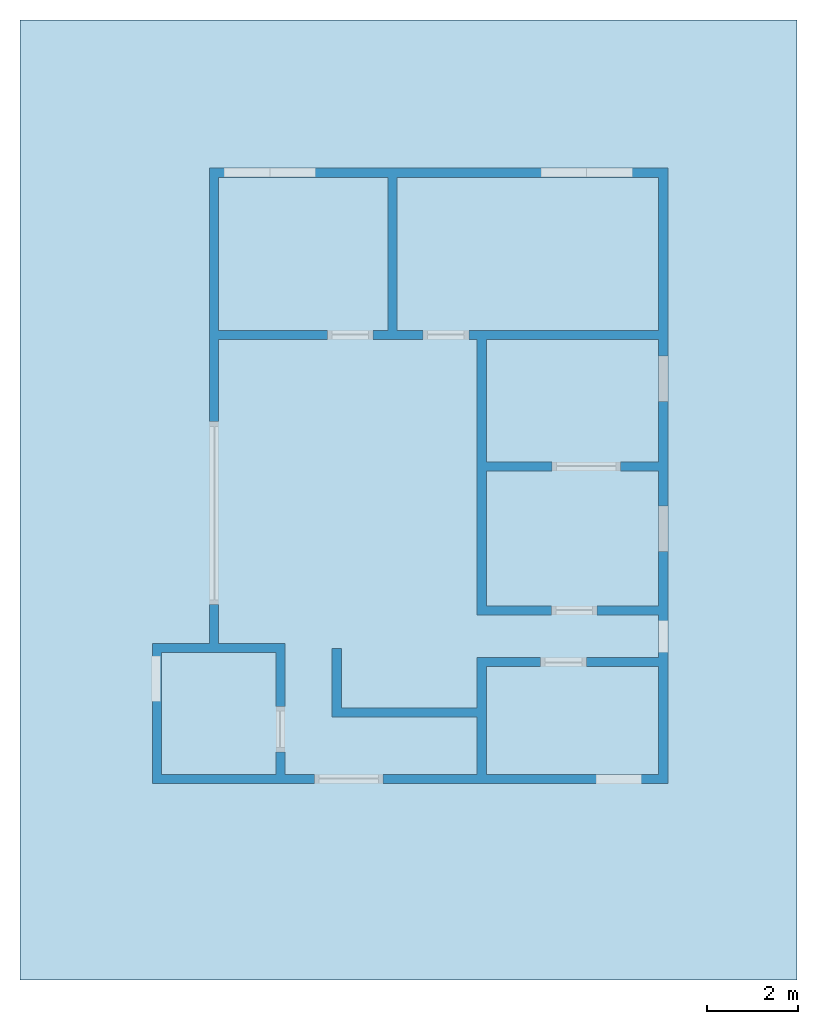
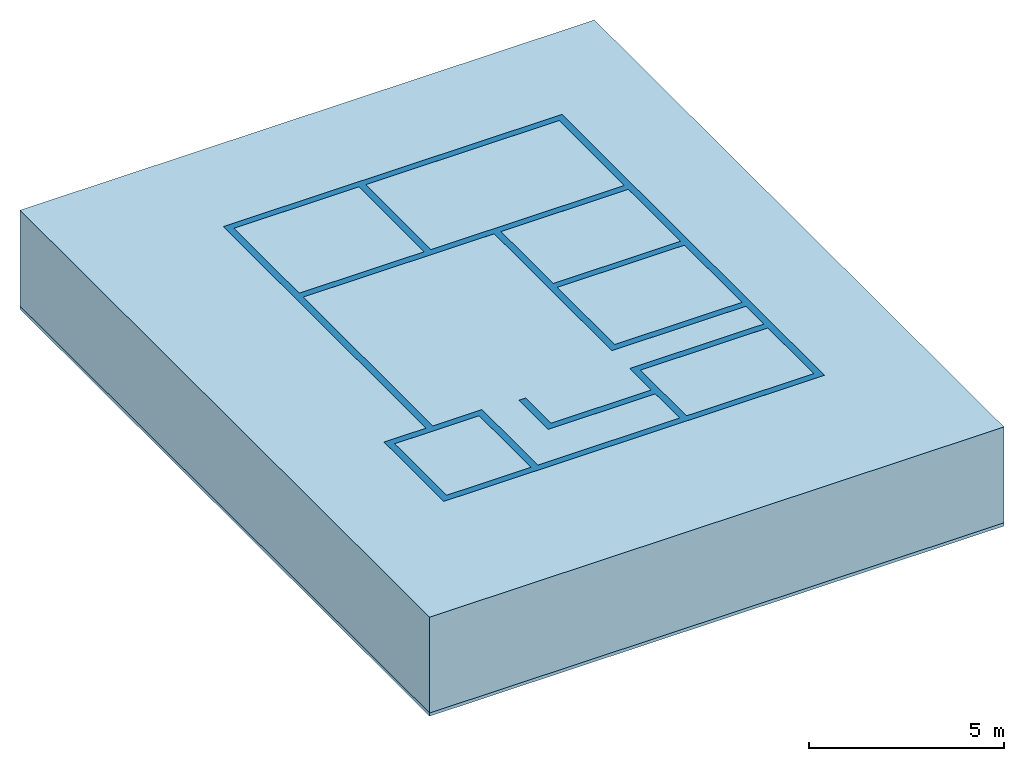
# Not in any storey, part 1 of 2: 2 plates, 1 wall, 17 openings.
"""IFC4 building model written with IfcOpenShell, lengths in metres."""

from ifc_helpers import new_model, entity, si_unit, converted_unit, direction, frame, frame_2d, origin_with_axes, place, context, subcontext, project, spatial, polyline, rectangle, outline, extrude, faceted_brep, element, save


model = new_model("IFC4")

# Units and contexts
model_context = context("Model", 3, precision=1e-05, world=origin_with_axes(), true_north=direction((0.0, 1.0)))
body_context = subcontext(model_context, "Body", "Model", "MODEL_VIEW")
ifc_project = project(units=[si_unit("LENGTHUNIT", "METRE"), si_unit("AREAUNIT", "SQUARE_METRE"), si_unit("VOLUMEUNIT", "CUBIC_METRE"), converted_unit("PLANEANGLEUNIT", "DEGREE", entity("IfcPlaneAngleMeasure", 0.017453292519943295), si_unit("PLANEANGLEUNIT", "RADIAN"), dimensions=[0, 0, 0, 0, 0, 0, 0])], contexts=[model_context])

# Building
building = spatial("IfcBuilding", Name="002", CompositionType="COMPLEX")

# Plates
placement = place(None, origin_with_axes())
element("IfcPlate", 1, at=placement, inside=building, Name="Panel", PredefinedType="CURTAIN_PANEL", context=body_context, shape_type="Brep", body=[
    faceted_brep([(14.0, -6.0, -0.1), (14.0, -6.0, 0.0), (-3.0, -6.0, 0.0), (-3.0, -6.0, -0.1), (14.0, 15.0, -0.1), (14.0, 15.0, 0.0), (-3.0, 15.0, -0.1), (-3.0, 15.0, 0.0)], [[[0, 1, 2, 3]], [[4, 5, 1, 0]], [[6, 7, 5, 4]], [[3, 2, 7, 6]], [[6, 4, 0, 3]], [[2, 1, 5, 7]]]),
])
element("IfcPlate", 2, at=placement, inside=building, Name="Panel001", PredefinedType="CURTAIN_PANEL", context=body_context, shape_type="Brep", body=[
    faceted_brep([(14.0, -6.0, 0.0), (14.0, -6.0, 3.0), (-3.0, -6.0, 3.0), (-3.0, -6.0, 0.0), (14.0, 15.0, 0.0), (14.0, 15.0, 3.0), (-3.0, 15.0, 0.0), (-3.0, 15.0, 3.0)], [[[0, 1, 2, 3]], [[4, 5, 1, 0]], [[6, 7, 5, 4]], [[3, 2, 7, 6]], [[6, 4, 0, 3]], [[2, 1, 5, 7]]]),
])

# Wall, openings
wall = element("IfcWall", 3, at=placement, inside=building, Name="Wall004", PredefinedType="MOVABLE", context=body_context, shape_type="SweptSolid", body=[
    extrude(outline(polyline([(-1.19834792122561, 1.18665207877462), (-1.19834792122538, -0.313347921225383), (2.07165207877462, -0.313347921225383), (2.0716520787743, -0.113347921225383), (-0.998347921226014, -0.113347921225385), (-0.998347921225923, 1.18665207877461), (-1.19834792122561, 1.18665207877462)])), frame((5.02834792122538, 0.0633479212253828, 0.0), z_axis=(0.0, 0.0, 1.0), x_axis=(1.0, 0.0, 0.0)), (0.0, 0.0, 1.0), 3.0),
    extrude(rectangle(XDim=3.55, YDim=0.2, at=frame_2d((0.116652078773768, 9.82165207877462), x_axis=(0.0, 1.0))), frame((5.02834792122538, 0.0633479212253828, 0.0), z_axis=(0.0, 0.0, 1.0), x_axis=(1.0, 0.0, 0.0)), (0.0, 0.0, 1.0), 3.0),
    extrude(rectangle(XDim=3.97, YDim=0.2, at=frame_2d((4.05665207877428, 5.1666520787746), x_axis=(1.0, 0.0))), frame((5.02834792122538, 0.0633479212253828, 0.0), z_axis=(0.0, 0.0, 1.0), x_axis=(1.0, 0.0, 0.0)), (0.0, 0.0, 1.0), 3.0),
    extrude(outline(polyline([(6.04165207877428, 0.996652078774617), (1.97165207877462, 0.996652078774617), (1.97165207877462, -1.56334792122538), (-2.22834792122538, -1.56334792122538), (-2.22834792122538, 1.29665207877462), (-3.68334792122538, 1.29665207877462), (-3.68334792122538, 7.94665207877462), (1.97165207877462, 7.94665207877462), (1.97165207877462, 1.91665207877462), (6.04165207877462, 1.91665207877462), (6.04165207877434, 2.11665207877462), (2.17165207877406, 2.11665207877462), (2.17165207877437, 8.14665207877462), (-3.88334792122532, 8.14665207877462), (-3.88334792122536, 1.09665207877461), (-2.4283479212254, 1.09665207877461), (-2.42834792122567, -1.76334792122539), (2.17165207877406, -1.76334792122539), (2.171652078774, 0.796652078774613), (6.04165207877395, 0.796652078774615), (6.04165207877428, 0.996652078774617)])), frame((5.02834792122538, 0.0633479212253828, 0.0), z_axis=(0.0, 0.0, 1.0), x_axis=(1.0, 0.0, 0.0)), (0.0, 0.0, 1.0), 3.0),
    extrude(outline(polyline([(-3.78334792122563, 1.09665207877461), (-4.92834792122538, 1.09665207877462), (-4.92834792122538, -1.56334792122538), (-2.32834792122538, -1.56334792122538), (-2.32834792122575, -1.76334792122539), (-5.12834792122612, -1.76334792122539), (-5.12834792122599, 1.29665207877461), (-3.78334792122587, 1.29665207877461), (-3.78334792122563, 1.09665207877461)])), frame((5.02834792122538, 0.0633479212253828, 0.0), z_axis=(0.0, 0.0, 1.0), x_axis=(1.0, 0.0, 0.0)), (0.0, 0.0, 1.0), 3.0),
    extrude(outline(polyline([(-3.68334792122544, 8.04665207877462), (-3.68334792122538, 11.4966520787746), (5.94165207877462, 11.4966520787746), (5.94165207877462, -1.56334792122538), (2.07165207877462, -1.56334792122538), (2.07165207877447, -1.76334792122539), (6.14165207877431, -1.76334792122539), (6.1416520787745, 11.6966520787746), (-3.88334792122532, 11.6966520787746), (-3.88334792122541, 8.04665207877461), (-3.68334792122544, 8.04665207877462)])), frame((5.02834792122538, 0.0633479212253828, 0.0), z_axis=(0.0, 0.0, 1.0), x_axis=(1.0, 0.0, 0.0)), (0.0, 0.0, 1.0), 3.0),
    extrude(rectangle(XDim=3.97, YDim=0.2, at=frame_2d((4.05665207877428, 8.04665207877461), x_axis=(1.0, 0.0))), frame((5.02834792122538, 0.0633479212253828, 0.0), z_axis=(0.0, 0.0, 1.0), x_axis=(1.0, 0.0, 0.0)), (0.0, 0.0, 1.0), 3.0),
])
element("IfcOpeningElement", 4, at=placement, cuts=wall, Name="006", context=body_context, shape_type="Brep", body=[
    faceted_brep([(2.299520508, -0.012117431640625, 0.0), (3.299520508, -0.012117431640625, 0.0), (3.299520508, -1.01211743164062, 0.0), (2.299520508, -1.01211743164062, 0.0), (2.299520508, -0.012117431640625, 2.1), (3.299520508, -0.012117431640625, 2.1), (2.299520508, -1.01211743164062, 2.1), (3.299520508, -1.01211743164062, 2.1)], [[[0, 1, 2, 3]], [[4, 5, 1, 0]], [[6, 7, 5, 4]], [[3, 2, 7, 6]], [[6, 4, 0, 3]], [[2, 1, 5, 7]]]),
])
element("IfcOpeningElement", 5, at=placement, cuts=wall, Name="009", context=body_context, shape_type="Brep", body=[
    faceted_brep([(4.7253876953125, 10.10997583, -4.2e-16), (4.7253876953125, 5.90997583, 4.2e-16), (3.7253876953125, 5.90997583, 4.2e-16), (3.7253876953125, 10.10997583, -4.2e-16), (4.7253876953125, 10.10997583, 2.1), (4.7253876953125, 5.90997583, 2.1), (3.7253876953125, 10.10997583, 2.1), (3.7253876953125, 5.90997583, 2.1)], [[[0, 1, 2, 3]], [[4, 5, 1, 0]], [[6, 7, 5, 4]], [[3, 2, 7, 6]], [[6, 4, 0, 3]], [[2, 1, 5, 7]]]),
])
element("IfcOpeningElement", 6, at=placement, cuts=wall, Name="010", context=body_context, shape_type="Brep", body=[
    faceted_brep([(2.46358325195312, 10.766516357, 1.48285754394531), (2.46358325195312, 12.766516357, 1.48285754394531), (3.46358325195312, 12.766516357, 1.48285754394531), (3.46358325195312, 10.766516357, 1.48285754394531), (2.46358325195312, 10.766516357, 2.48285754394531), (2.46358325195312, 12.766516357, 2.48285754394531), (3.46358325195312, 10.766516357, 2.48285754394531), (3.46358325195312, 12.766516357, 2.48285754394531)], [[[0, 1, 2, 3]], [[4, 5, 1, 0]], [[6, 7, 5, 4]], [[3, 2, 7, 6]], [[6, 4, 0, 3]], [[2, 1, 5, 7]]]),
])
element("IfcOpeningElement", 7, at=placement, cuts=wall, Name="011", context=body_context, shape_type="Brep", body=[
    faceted_brep([(1.46358325195313, 10.766516357, 1.48285754394531), (1.46358325195313, 12.766516357, 1.48285754394531), (2.46358325195312, 12.766516357, 1.48285754394531), (2.46358325195312, 10.766516357, 1.48285754394531), (1.46358325195313, 10.766516357, 2.48285754394531), (1.46358325195313, 12.766516357, 2.48285754394531), (2.46358325195312, 10.766516357, 2.48285754394531), (2.46358325195312, 12.766516357, 2.48285754394531)], [[[0, 1, 2, 3]], [[4, 5, 1, 0]], [[6, 7, 5, 4]], [[3, 2, 7, 6]], [[6, 4, 0, 3]], [[2, 1, 5, 7]]]),
])
element("IfcOpeningElement", 8, at=placement, cuts=wall, Name="012", context=body_context, shape_type="Brep", body=[
    faceted_brep([(9.394705078125, 10.766516357, 1.477650390625), (9.394705078125, 12.766516357, 1.477650390625), (10.394705078125, 12.766516357, 1.477650390625), (10.394705078125, 10.766516357, 1.477650390625), (9.394705078125, 10.766516357, 2.477650390625), (9.394705078125, 12.766516357, 2.477650390625), (10.394705078125, 10.766516357, 2.477650390625), (10.394705078125, 12.766516357, 2.477650390625)], [[[0, 1, 2, 3]], [[4, 5, 1, 0]], [[6, 7, 5, 4]], [[3, 2, 7, 6]], [[6, 4, 0, 3]], [[2, 1, 5, 7]]]),
])
element("IfcOpeningElement", 9, at=placement, cuts=wall, Name="013", context=body_context, shape_type="Brep", body=[
    faceted_brep([(8.394705078125, 10.766516357, 1.477650390625), (8.394705078125, 12.766516357, 1.477650390625), (9.394705078125, 12.766516357, 1.477650390625), (9.394705078125, 10.766516357, 1.477650390625), (8.394705078125, 10.766516357, 2.477650390625), (8.394705078125, 12.766516357, 2.477650390625), (9.394705078125, 10.766516357, 2.477650390625), (9.394705078125, 12.766516357, 2.477650390625)], [[[0, 1, 2, 3]], [[4, 5, 1, 0]], [[6, 7, 5, 4]], [[3, 2, 7, 6]], [[6, 4, 0, 3]], [[2, 1, 5, 7]]]),
])
element("IfcOpeningElement", 10, at=placement, cuts=wall, Name="014", context=body_context, shape_type="Brep", body=[
    faceted_brep([(0.872182634, 0.09050927734375, 1.20494030761719), (-1.127817366, 0.09050927734375, 1.20494030761719), (-1.127817366, 1.09050927734375, 1.20494030761719), (0.872182634, 1.09050927734375, 1.20494030761719), (0.872182634, 0.09050927734375, 2.20494030761719), (-1.127817366, 0.09050927734375, 2.20494030761719), (0.872182634, 1.09050927734375, 2.20494030761719), (-1.127817366, 1.09050927734375, 2.20494030761719)], [[[0, 1, 2, 3]], [[4, 5, 1, 0]], [[6, 7, 5, 4]], [[3, 2, 7, 6]], [[6, 4, 0, 3]], [[2, 1, 5, 7]]]),
])
element("IfcOpeningElement", 11, at=placement, cuts=wall, Name="015", context=body_context, shape_type="Brep", body=[
    faceted_brep([(10.595484375, -0.709431519, 1.23817114257812), (10.595484375, -2.709431519, 1.23817114257813), (9.595484375, -2.709431519, 1.23817114257813), (9.595484375, -0.709431519, 1.23817114257812), (10.595484375, -0.709431519, 2.23817114257813), (10.595484375, -2.709431519, 2.23817114257813), (9.595484375, -0.709431519, 2.23817114257813), (9.595484375, -2.709431519, 2.23817114257813)], [[[0, 1, 2, 3]], [[4, 5, 1, 0]], [[6, 7, 5, 4]], [[3, 2, 7, 6]], [[6, 4, 0, 3]], [[2, 1, 5, 7]]]),
])
element("IfcOpeningElement", 12, at=placement, cuts=wall, Name="017", context=body_context, shape_type="Brep", body=[
    faceted_brep([(10.13672265625, 7.231109375, -4.2e-16), (10.13672265625, 3.031109375, 4.2e-16), (8.63672265625, 3.031109375, 4.2e-16), (8.63672265625, 7.231109375, -4.2e-16), (10.13672265625, 7.231109375, 2.1), (10.13672265625, 3.031109375, 2.1), (8.63672265625, 7.231109375, 2.1), (8.63672265625, 3.031109375, 2.1)], [[[0, 1, 2, 3]], [[4, 5, 1, 0]], [[6, 7, 5, 4]], [[3, 2, 7, 6]], [[6, 4, 0, 3]], [[2, 1, 5, 7]]]),
])
element("IfcOpeningElement", 13, at=placement, cuts=wall, Name="018", context=body_context, shape_type="Brep", body=[
    faceted_brep([(10.170980469, 4.37278393554687, 1.16492016601562), (12.170980469, 4.37278393554687, 1.16492016601562), (12.170980469, 3.37278393554688, 1.16492016601562), (10.170980469, 3.37278393554688, 1.16492016601562), (10.170980469, 4.37278393554687, 2.16492016601563), (12.170980469, 4.37278393554687, 2.16492016601563), (10.170980469, 3.37278393554688, 2.16492016601563), (12.170980469, 3.37278393554688, 2.16492016601563)], [[[0, 1, 2, 3]], [[4, 5, 1, 0]], [[6, 7, 5, 4]], [[3, 2, 7, 6]], [[6, 4, 0, 3]], [[2, 1, 5, 7]]]),
])
element("IfcOpeningElement", 14, at=placement, cuts=wall, Name="019", context=body_context, shape_type="Brep", body=[
    faceted_brep([(10.170980469, 7.6536171875, 1.10756701660156), (12.170980469, 7.6536171875, 1.10756701660156), (12.170980469, 6.6536171875, 1.10756701660156), (10.170980469, 6.6536171875, 1.10756701660156), (10.170980469, 7.6536171875, 2.10756701660156), (12.170980469, 7.6536171875, 2.10756701660156), (10.170980469, 6.6536171875, 2.10756701660156), (12.170980469, 6.6536171875, 2.10756701660156)], [[[0, 1, 2, 3]], [[4, 5, 1, 0]], [[6, 7, 5, 4]], [[3, 2, 7, 6]], [[6, 4, 0, 3]], [[2, 1, 5, 7]]]),
])
element("IfcOpeningElement", 15, at=placement, cuts=wall, context=body_context, shape_type="Brep", body=[
    faceted_brep([(10.170980469, 1.85942370605469, 1.64867785644531), (12.170980469, 1.85942370605469, 1.64867785644531), (12.170980469, 1.15942370605469, 1.64867785644531), (10.170980469, 1.15942370605469, 1.64867785644531), (10.170980469, 1.85942370605469, 2.64867785644531), (12.170980469, 1.85942370605469, 2.64867785644531), (10.170980469, 1.15942370605469, 2.64867785644531), (12.170980469, 1.15942370605469, 2.64867785644531)], [[[0, 1, 2, 3]], [[4, 5, 1, 0]], [[6, 7, 5, 4]], [[3, 2, 7, 6]], [[6, 4, 0, 3]], [[2, 1, 5, 7]]]),
])
element("IfcOpeningElement", 16, at=placement, cuts=wall, Name="020", context=body_context, shape_type="Brep", body=[
    faceted_brep([(4.93684497070312, -1.5, -4e-17), (4.93684497070312, -1.9, 4e-17), (3.43684497070313, -1.9, 4e-17), (3.43684497070313, -1.5, -4e-17), (4.93684497070312, -1.5, 2.1), (4.93684497070312, -1.9, 2.1), (3.43684497070313, -1.5, 2.1), (3.43684497070313, -1.9, 2.1)], [[[0, 1, 2, 3]], [[4, 5, 1, 0]], [[6, 7, 5, 4]], [[3, 2, 7, 6]], [[6, 4, 0, 3]], [[2, 1, 5, 7]]]),
])
element("IfcOpeningElement", 17, at=placement, cuts=wall, Name="021", context=body_context, shape_type="Brep", body=[
    faceted_brep([(9.6232451171875, 2.18, -4e-17), (9.6232451171875, 1.78, 4e-17), (8.6232451171875, 1.78, 4e-17), (8.6232451171875, 2.18, -4e-17), (9.6232451171875, 2.18, 2.1), (9.6232451171875, 1.78, 2.1), (8.6232451171875, 2.18, 2.1), (8.6232451171875, 1.78, 2.1)], [[[0, 1, 2, 3]], [[4, 5, 1, 0]], [[6, 7, 5, 4]], [[3, 2, 7, 6]], [[6, 4, 0, 3]], [[2, 1, 5, 7]]]),
])
element("IfcOpeningElement", 18, at=placement, cuts=wall, Name="007", context=body_context, shape_type="Brep", body=[
    faceted_brep([(8.3892021484375, 0.859165588, 4e-17), (8.3892021484375, 1.259165588, -4e-17), (9.3892021484375, 1.259165588, -4e-17), (9.3892021484375, 0.859165588, 4e-17), (8.3892021484375, 0.859165588, 2.1), (8.3892021484375, 1.259165588, 2.1), (9.3892021484375, 0.859165588, 2.1), (9.3892021484375, 1.259165588, 2.1)], [[[0, 1, 2, 3]], [[4, 5, 1, 0]], [[6, 7, 5, 4]], [[3, 2, 7, 6]], [[6, 4, 0, 3]], [[2, 1, 5, 7]]]),
])
element("IfcOpeningElement", 19, at=placement, cuts=wall, Name="022", context=body_context, shape_type="Brep", body=[
    faceted_brep([(6.81764013671875, 10.11, -4.2e-16), (6.81764013671875, 5.91, 4.2e-16), (5.81764013671875, 5.91, 4.2e-16), (5.81764013671875, 10.11, -4.2e-16), (6.81764013671875, 10.11, 2.1), (6.81764013671875, 5.91, 2.1), (5.81764013671875, 10.11, 2.1), (5.81764013671875, 5.91, 2.1)], [[[0, 1, 2, 3]], [[4, 5, 1, 0]], [[6, 7, 5, 4]], [[3, 2, 7, 6]], [[6, 4, 0, 3]], [[2, 1, 5, 7]]]),
])
element("IfcOpeningElement", 20, at=placement, cuts=wall, Name="023", context=body_context, shape_type="Brep", body=[
    faceted_brep([(5.145, 2.2117607421875, 0.0), (-2.855, 2.2117607421875, 0.0), (-2.855, 6.2117607421875, 0.0), (5.145, 6.2117607421875, 0.0), (5.145, 2.2117607421875, 2.1), (-2.855, 2.2117607421875, 2.1), (5.145, 6.2117607421875, 2.1), (-2.855, 6.2117607421875, 2.1)], [[[0, 1, 2, 3]], [[4, 5, 1, 0]], [[6, 7, 5, 4]], [[3, 2, 7, 6]], [[6, 4, 0, 3]], [[2, 1, 5, 7]]]),
])

save(model, "model.ifc")
